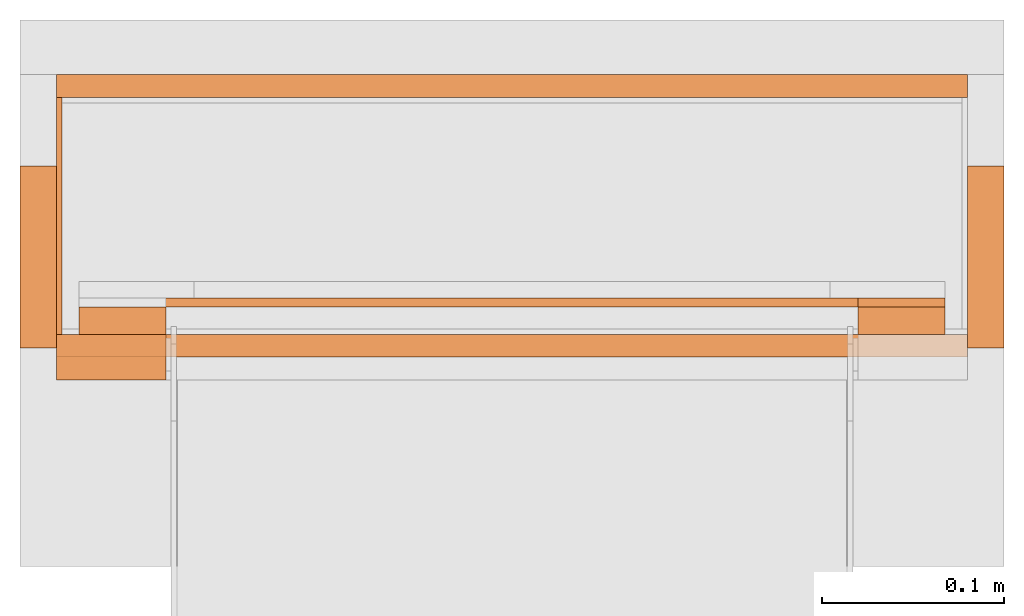
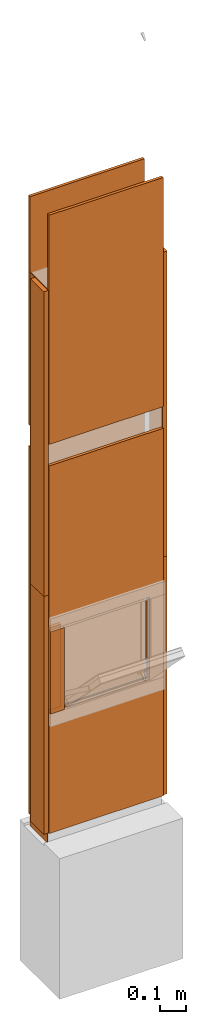
# One storey, part 1 of 4: 15 proxies, 1 opening.
"""IFC2X3 building model written with IfcOpenShell, lengths in metres."""

from ifc_helpers import new_model, entity, si_unit, converted_unit, derived_unit, money_unit, direction, frame, origin_with_axes, origin_2d_with_axis, place, context, subcontext, project, spatial, polyline, rectangle, outline, extrude, material, type_object, element, save


model = new_model("IFC2X3")

# Units and contexts
model_context = context("Model", 3, precision=1e-05, world=origin_with_axes(), true_north=direction((0.0, 1.0)))
plan_context = context("Plan", 3, precision=1e-05, world=origin_with_axes(), true_north=direction((0.0, 1.0)))
body_context = subcontext(model_context, "Body", "Model", "MODEL_VIEW")
ifc_project = project(units=[si_unit("LENGTHUNIT", "METRE"), si_unit("AREAUNIT", "SQUARE_METRE"), si_unit("VOLUMEUNIT", "CUBIC_METRE"), converted_unit("PLANEANGLEUNIT", "DEGREE", entity("IfcPlaneAngleMeasure", 0.0174532925199), si_unit("PLANEANGLEUNIT", "RADIAN"), dimensions=[0, 0, 0, 0, 0, 0, 0]), si_unit("SOLIDANGLEUNIT", "STERADIAN"), money_unit("CHF"), converted_unit("TIMEUNIT", "Year", entity("IfcTimeMeasure", 31556926.0), si_unit("TIMEUNIT", "SECOND"), dimensions=[0, 0, 1, 0, 0, 0, 0]), si_unit("MASSUNIT", "GRAM", prefix="KILO"), si_unit("THERMODYNAMICTEMPERATUREUNIT", "DEGREE_CELSIUS"), si_unit("LUMINOUSINTENSITYUNIT", "LUMEN"), si_unit("ENERGYUNIT", "JOULE", prefix="MEGA"), derived_unit("THERMALCONDUCTANCEUNIT", [(si_unit("POWERUNIT", "WATT"), 1), (si_unit("LENGTHUNIT", "METRE"), -1), (si_unit("THERMODYNAMICTEMPERATUREUNIT", "KELVIN"), -1)]), derived_unit("SPECIFICHEATCAPACITYUNIT", [(si_unit("ENERGYUNIT", "JOULE"), 1), (si_unit("MASSUNIT", "GRAM", prefix="KILO"), -1), (si_unit("THERMODYNAMICTEMPERATUREUNIT", "KELVIN"), -1)]), derived_unit("MASSDENSITYUNIT", [(si_unit("MASSUNIT", "GRAM", prefix="KILO"), 1), (si_unit("VOLUMEUNIT", "CUBIC_METRE"), -1)])], contexts=[model_context, plan_context])

# Site, building, storey
site_placement = place(None, origin_with_axes())
site = spatial("IfcSite", under=ifc_project, at=site_placement, CompositionType="ELEMENT")
building_placement = place(site_placement, origin_with_axes())
building = spatial("IfcBuilding", under=site, at=building_placement, CompositionType="ELEMENT")
storey_placement = place(building_placement, origin_with_axes())
storey = spatial("IfcBuildingStorey", under=building, at=storey_placement, Name="EG00", CompositionType="ELEMENT", Elevation=0.0)

# Proxies
ifc_material_1 = material(Name="Metall, Stahl")
building_element_proxy_type_1 = type_object("IfcBuildingElementProxyType", Name="Metall, Stahl 3", PredefinedType="NOTDEFINED")
proxy_1_placement = place(storey_placement, frame((9.11522436818, -8.09743070606, 0.0), z_axis=(0.0, 0.0, 1.0), x_axis=(0.0, -1.0, 0.0)))
element("IfcBuildingElementProxy", 1, at=proxy_1_placement, inside=storey, type_object=building_element_proxy_type_1, material=ifc_material_1, Name="Wand-005", context=body_context, shape_type="SweptSolid", body=[
    extrude(outline(polyline([(0.0, 0.0), (0.13, 0.0), (0.13, 0.003), (0.0, 0.003), (0.0, 0.0)])), origin_with_axes(), (0.0, 0.0, 1.0), 1.15),
])
proxy_2_placement = place(storey_placement, frame((9.11522436818, -8.09743070606, 1.15), z_axis=(0.0, 0.0, 1.0), x_axis=(0.0, -1.0, 0.0)))
element("IfcBuildingElementProxy", 2, at=proxy_2_placement, inside=storey, type_object=building_element_proxy_type_1, material=ifc_material_1, Name="Wand-005", context=body_context, shape_type="SweptSolid", body=[
    extrude(outline(polyline([(0.0, 0.0), (0.13, 0.0), (0.13, 0.003), (0.0, 0.003), (0.0, 0.0)])), origin_with_axes(), (0.0, 0.0, 1.0), 1.41),
])
ifc_material_2 = material(Name="Holz")
building_element_proxy_type_2 = type_object("IfcBuildingElementProxyType", Name="Holz 15", PredefinedType="NOTDEFINED")
for number, where, z_axis, x_axis, name in (
    (3, (9.12772436818, -8.22743070606, 0.61), (0.0, 0.0, 1.0), (1.0, 0.0, 0.0), "Wand-004"),
    (4, (9.55522436818, -8.22743070606, 0.61), (0.0, 0.0, 1.0), (1.0, 0.0, 0.0), "Wand-004"),
):
    element("IfcBuildingElementProxy", number, at=place(storey_placement, frame(where, z_axis=z_axis, x_axis=x_axis)), inside=storey, type_object=building_element_proxy_type_2, material=ifc_material_2, Name=name, context=body_context, shape_type="SweptSolid", body=[
        extrude(outline(polyline([(0.0, 0.0), (0.0475, 0.0), (0.0475, 0.015), (0.0, 0.015), (0.0, 0.0)])), origin_with_axes(), (0.0, 0.0, 1.0), 0.38),
    ])
building_element_proxy_type_3 = type_object("IfcBuildingElementProxyType", Name="Holz 5", PredefinedType="NOTDEFINED")
proxy_3_placement = place(storey_placement, frame((9.55522436818, -8.21243070606, 0.6), z_axis=(0.0, 0.0, 1.0), x_axis=(1.0, 0.0, 0.0)))
element("IfcBuildingElementProxy", 5, at=proxy_3_placement, inside=storey, type_object=building_element_proxy_type_3, material=ifc_material_2, Name="Wand-004", context=body_context, shape_type="SweptSolid", body=[
    extrude(outline(polyline([(0.0, 0.0), (0.0475, 0.0), (0.0475, 0.005), (0.0, 0.005), (0.0, 0.0)])), origin_with_axes(), (0.0, 0.0, 1.0), 0.4),
])
proxy_4_placement = place(storey_placement, frame((9.60272436818, -8.21243070606, 0.5625), z_axis=(0.0, 0.0, 1.0), x_axis=(-1.0, 0.0, 0.0)))
element("IfcBuildingElementProxy", 6, at=proxy_4_placement, inside=storey, type_object=building_element_proxy_type_3, material=ifc_material_2, Name="Wand-004", context=body_context, shape_type="SweptSolid", body=[
    extrude(outline(polyline([(0.0, -0.005), (0.475, -0.005), (0.475, 0.0), (0.0, 0.0), (0.0, -0.005)])), origin_with_axes(), (0.0, 0.0, 1.0), 0.0375),
])
building_element_proxy_type_4 = type_object("IfcBuildingElementProxyType", Name="Holz 25", PredefinedType="NOTDEFINED")
proxy_5_placement = place(storey_placement, frame((9.11522436818, -8.25243070606, 0.61), z_axis=(0.0, 0.0, 1.0), x_axis=(1.0, 0.0, 0.0)))
element("IfcBuildingElementProxy", 7, at=proxy_5_placement, inside=storey, type_object=building_element_proxy_type_4, material=ifc_material_2, Name="Wand-004", context=body_context, shape_type="SweptSolid", body=[
    extrude(outline(polyline([(0.0, 0.0), (0.06, 0.0), (0.06, 0.025), (0.0, 0.025), (0.0, 0.0)])), origin_with_axes(), (0.0, 0.0, 1.0), 0.38),
])

# Proxy, opening
ifc_material_3 = material(Name="Gipsplatte horizontal")
building_element_proxy_type_5 = type_object("IfcBuildingElementProxyType", Name="Gipsplatte horizontal 13", PredefinedType="NOTDEFINED")
proxy_6_placement = place(storey_placement, frame((9.11522436818, -8.23993070606, 0.05), z_axis=(0.0, 0.0, 1.0), x_axis=(1.0, 0.0, 0.0)))
proxy_6 = element("IfcBuildingElementProxy", 8, at=proxy_6_placement, inside=storey, type_object=building_element_proxy_type_5, material=ifc_material_3, Name="Wand-004", context=body_context, shape_type="SweptSolid", body=[
    extrude(outline(polyline([(0.0, 0.0), (0.5, 0.0), (0.5, 0.0125), (0.0, 0.0125), (0.0, 0.0)])), origin_with_axes(), (0.0, 0.0, 1.0), 1.7),
])
opening_placement = place(proxy_6_placement, frame((-9.11522436818, 8.23993070606, -0.05), z_axis=(0.0, 0.0, 1.0), x_axis=(1.0, 0.0, 0.0)))
element("IfcOpeningElement", 9, at=opening_placement, cuts=proxy_6, Name="030", context=body_context, shape_type="SweptSolid", body=[
    extrude(rectangle(XDim=0.38, YDim=0.38, at=origin_2d_with_axis()), frame((9.36522436818, -8.25243070606, 0.8), z_axis=(0.0, -1.0, 0.0), x_axis=(1.0, 0.0, 0.0)), (0.0, 0.0, -1.0), 0.0375),
])

# Proxies
proxy_7_placement = place(storey_placement, frame((9.11522436818, -8.08493070606, 0.05), z_axis=(0.0, 0.0, 1.0), x_axis=(1.0, 0.0, 0.0)))
element("IfcBuildingElementProxy", 10, at=proxy_7_placement, inside=storey, type_object=building_element_proxy_type_5, material=ifc_material_3, Name="Wand-004", context=body_context, shape_type="SweptSolid", body=[
    extrude(outline(polyline([(0.0, -0.0125), (0.5, -0.0125), (0.5, 0.0), (0.0, 0.0), (0.0, -0.0125)])), origin_with_axes(), (0.0, 0.0, 1.0), 1.7),
])
proxy_8_placement = place(storey_placement, frame((9.11522436818, -8.23993070606, 1.85), z_axis=(0.0, 0.0, 1.0), x_axis=(1.0, 0.0, 0.0)))
element("IfcBuildingElementProxy", 11, at=proxy_8_placement, inside=storey, type_object=building_element_proxy_type_5, material=ifc_material_3, Name="Wand-004", context=body_context, shape_type="SweptSolid", body=[
    extrude(outline(polyline([(0.0, 0.0), (0.5, 0.0), (0.5, 0.0125), (0.0, 0.0125), (0.0, 0.0)])), origin_with_axes(), (0.0, 0.0, 1.0), 1.06),
])
proxy_9_placement = place(storey_placement, frame((9.11522436818, -8.08493070606, 1.85), z_axis=(0.0, 0.0, 1.0), x_axis=(1.0, 0.0, 0.0)))
element("IfcBuildingElementProxy", 12, at=proxy_9_placement, inside=storey, type_object=building_element_proxy_type_5, material=ifc_material_3, Name="Wand-004", context=body_context, shape_type="SweptSolid", body=[
    extrude(outline(polyline([(0.0, -0.0125), (0.5, -0.0125), (0.5, 0.0), (0.0, 0.0), (0.0, -0.0125)])), origin_with_axes(), (0.0, 0.0, 1.0), 1.06),
])
building_element_proxy_type_6 = type_object("IfcBuildingElementProxyType", Name="Holz 20", PredefinedType="NOTDEFINED")
proxy_10_placement = place(storey_placement, frame((9.09522436818, -8.13493070606, 0.05), z_axis=(0.0, 0.0, 1.0), x_axis=(0.0, -1.0, 0.0)))
element("IfcBuildingElementProxy", 13, at=proxy_10_placement, inside=storey, type_object=building_element_proxy_type_6, material=ifc_material_2, Name="Wand-004", context=body_context, shape_type="SweptSolid", body=[
    extrude(outline(polyline([(0.0, 0.0), (0.1, 0.0), (0.1, 0.02), (0.0, 0.02), (0.0, 0.0)])), origin_with_axes(), (0.0, 0.0, 1.0), 1.1),
])
proxy_11_placement = place(storey_placement, frame((9.63522436818, -8.13493070606, 0.05), z_axis=(0.0, 0.0, 1.0), x_axis=(0.0, -1.0, 0.0)))
element("IfcBuildingElementProxy", 14, at=proxy_11_placement, inside=storey, type_object=building_element_proxy_type_6, material=ifc_material_2, Name="Wand-003", context=body_context, shape_type="SweptSolid", body=[
    extrude(outline(polyline([(0.0, -0.02), (0.1, -0.02), (0.1, 0.0), (0.0, 0.0), (0.0, -0.02)])), origin_with_axes(), (0.0, 0.0, 1.0), 1.1),
])
proxy_12_placement = place(storey_placement, frame((9.09522436818, -8.13493070606, 1.15), z_axis=(0.0, 0.0, 1.0), x_axis=(0.0, -1.0, 0.0)))
element("IfcBuildingElementProxy", 15, at=proxy_12_placement, inside=storey, type_object=building_element_proxy_type_6, material=ifc_material_2, Name="Wand-004", context=body_context, shape_type="SweptSolid", body=[
    extrude(outline(polyline([(0.0, 0.0), (0.1, 0.0), (0.1, 0.02), (0.0, 0.02), (0.0, 0.0)])), origin_with_axes(), (0.0, 0.0, 1.0), 1.41),
])
proxy_13_placement = place(storey_placement, frame((9.63522436818, -8.13493070606, 1.15), z_axis=(0.0, 0.0, 1.0), x_axis=(0.0, -1.0, 0.0)))
element("IfcBuildingElementProxy", 16, at=proxy_13_placement, inside=storey, type_object=building_element_proxy_type_6, material=ifc_material_2, Name="Wand-003", context=body_context, shape_type="SweptSolid", body=[
    extrude(outline(polyline([(0.0, -0.02), (0.1, -0.02), (0.1, 0.0), (0.0, 0.0), (0.0, -0.02)])), origin_with_axes(), (0.0, 0.0, 1.0), 1.41),
])

save(model, "model.ifc")
